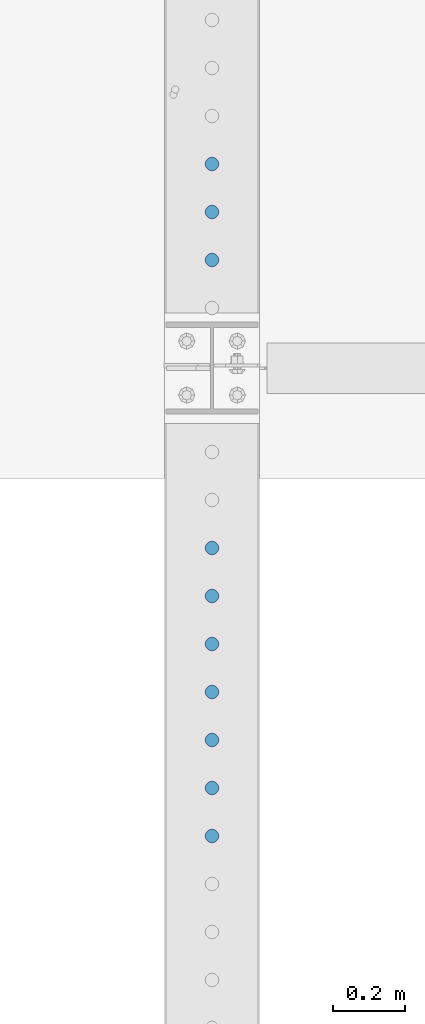
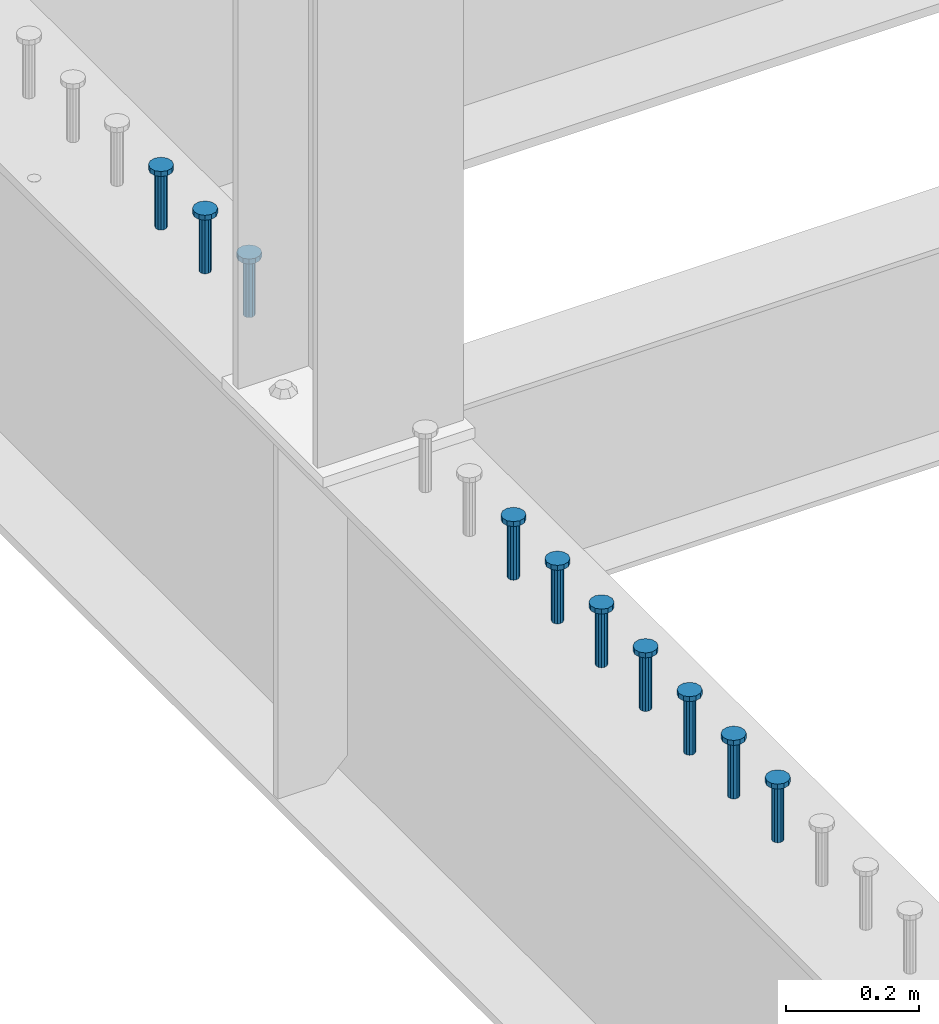
# One storey, part 949 of 1763: 10 columns, 10 elements without a shape of their own.
"""IFC2X3 building model written with IfcOpenShell, lengths in millimetres."""

from ifc_helpers import new_model, si_unit, frame, origin_with_axes, place, context, subcontext, project, spatial, faceted_brep, material, type_object, element, aggregate, save


model = new_model("IFC2X3")

# Units and contexts
model_context = context("Model", 3, precision=1e-05, world=origin_with_axes())
body_context = subcontext(model_context, "Body", "Model", "MODEL_VIEW")
ifc_project = project(units=[si_unit("LENGTHUNIT", "METRE", prefix="MILLI"), si_unit("AREAUNIT", "SQUARE_METRE"), si_unit("VOLUMEUNIT", "CUBIC_METRE"), si_unit("MASSUNIT", "GRAM", prefix="KILO"), si_unit("TIMEUNIT", "SECOND"), si_unit("PLANEANGLEUNIT", "RADIAN"), si_unit("SOLIDANGLEUNIT", "STERADIAN"), si_unit("THERMODYNAMICTEMPERATUREUNIT", "DEGREE_CELSIUS"), si_unit("LUMINOUSINTENSITYUNIT", "LUMEN")], contexts=[model_context])

# Site, building, storey
site_placement = place(None, origin_with_axes())
site = spatial("IfcSite", under=ifc_project, at=site_placement, CompositionType="ELEMENT")
building_placement = place(site_placement, origin_with_axes())
building = spatial("IfcBuilding", under=site, at=building_placement, Name="Undefined", CompositionType="ELEMENT")
storey_placement = place(building_placement, origin_with_axes())
storey = spatial("IfcBuildingStorey", under=building, at=storey_placement, Name="Undefined", CompositionType="ELEMENT", Elevation=0.0)

# Assembly, column
assembly_1_placement = place(storey_placement, origin_with_axes())
assembly_1 = element("IfcElementAssembly", 1, at=assembly_1_placement, inside=storey, Name="STUD", AssemblyPlace="NOTDEFINED", PredefinedType="RIGID_FRAME")
ifc_material = material(Name="STEEL/A108")
column_type = type_object("IfcColumnType", Name="STUD_3/4-DIA", PredefinedType="NOTDEFINED")
column_1_placement = place(assembly_1_placement, frame((-24027.8372736984, 43845.6785, 5194.3), z_axis=(-1.0, 0.0, 0.0), x_axis=(0.0, 0.0, 1.0)))
column_1 = element("IfcColumn", 2, at=column_1_placement, type_object=column_type, material=ifc_material, Name="STUD", ObjectType="STUD_3/4-DIA", context=body_context, shape_type="Brep", body=[
    faceted_brep([(0.0, -9.52000045776367, 0.0), (0.0, -8.25, -4.76000022888184), (104.013, -8.25, -4.76000022888184), (104.013, -9.52000045776367, 0.0), (0.0, -4.76000022888184, -8.25), (104.013, -4.76000022888184, -8.25), (0.0, 0.0, -9.52000045776367), (104.013, 0.0, -9.52000045776367), (0.0, 4.76000022888184, -8.25), (104.013, 4.76000022888184, -8.25), (0.0, 8.25, -4.76000022888184), (104.013, 8.25, -4.76000022888184), (0.0, 9.52000045776367, 0.0), (104.013, 9.52000045776367, 0.0), (0.0, 8.25, 4.76000022888184), (104.013, 8.25, 4.76000022888184), (0.0, 4.76000022888184, 8.25), (104.013, 4.76000022888184, 8.25), (0.0, 0.0, 9.52000045776367), (104.013, 0.0, 9.52000045776367), (0.0, -4.76000022888184, 8.25), (104.013, -4.76000022888184, 8.25), (0.0, -8.25, 4.76000022888184), (104.013, -8.25, 4.76000022888184), (105.156, -16.5, -9.52000045776367), (105.156, -19.0499992370605, 0.0), (105.156, -9.52000045776367, -16.5), (105.156, 0.0, -19.0499992370605), (105.156, 9.52000045776367, -16.5), (105.156, 16.5, -9.52000045776367), (105.156, 19.0499992370605, 0.0), (105.156, 16.5, 9.52000045776367), (105.156, 9.52000045776367, 16.5), (105.156, 0.0, 19.0499992370605), (105.156, -9.52000045776367, 16.5), (105.156, -16.5, 9.52000045776367), (114.3, -16.5, -9.52000045776367), (114.299998441489, -19.0500000000029, 0.0), (114.3, -9.52000045776367, -16.5), (114.3, 0.0, -19.0499992370605), (114.3, 9.52000045776367, -16.5), (114.3, 16.5, -9.52000045776367), (114.299998441489, 19.0500000000029, 0.0), (114.3, 16.5, 9.52000045776367), (114.3, 9.52000045776367, 16.5), (114.3, 0.0, 19.0499992370605), (114.3, -9.52000045776367, 16.5), (114.3, -16.5, 9.52000045776367)], [[[0, 1, 2, 3]], [[1, 4, 5, 2]], [[4, 6, 7, 5]], [[6, 8, 9, 7]], [[8, 10, 11, 9]], [[10, 12, 13, 11]], [[12, 14, 15, 13]], [[14, 16, 17, 15]], [[16, 18, 19, 17]], [[18, 20, 21, 19]], [[20, 22, 23, 21]], [[22, 0, 3, 23]], [[22, 20, 18, 16, 14, 12, 10, 8, 6, 4, 1, 0]], [[3, 2, 24, 25]], [[2, 5, 26, 24]], [[5, 7, 27, 26]], [[7, 9, 28, 27]], [[9, 11, 29, 28]], [[11, 13, 30, 29]], [[13, 15, 31, 30]], [[15, 17, 32, 31]], [[17, 19, 33, 32]], [[19, 21, 34, 33]], [[21, 23, 35, 34]], [[23, 3, 25, 35]], [[25, 24, 36, 37]], [[24, 26, 38, 36]], [[26, 27, 39, 38]], [[27, 28, 40, 39]], [[28, 29, 41, 40]], [[29, 30, 42, 41]], [[30, 31, 43, 42]], [[31, 32, 44, 43]], [[32, 33, 45, 44]], [[33, 34, 46, 45]], [[34, 35, 47, 46]], [[35, 25, 37, 47]], [[38, 39, 40, 41, 42, 43, 44, 45, 46, 47, 37, 36]]]),
])
aggregate(assembly_1, [column_1])

assembly_2_placement = place(storey_placement, origin_with_axes())
assembly_2 = element("IfcElementAssembly", 3, at=assembly_2_placement, inside=storey, Name="STUD", AssemblyPlace="NOTDEFINED", PredefinedType="RIGID_FRAME")
column_2_placement = place(assembly_2_placement, frame((-24027.8372736984, 43713.0705, 5194.3), z_axis=(-1.0, 0.0, 0.0), x_axis=(0.0, 0.0, 1.0)))
column_2 = element("IfcColumn", 4, at=column_2_placement, type_object=column_type, material=ifc_material, Name="STUD", ObjectType="STUD_3/4-DIA", context=body_context, shape_type="Brep", body=[
    faceted_brep([(0.0, -9.52000045776367, 0.0), (0.0, -8.25, -4.76000022888184), (104.013, -8.25, -4.76000022888184), (104.013, -9.52000045776367, 0.0), (0.0, -4.76000022888184, -8.25), (104.013, -4.76000022888184, -8.25), (0.0, 0.0, -9.52000045776367), (104.013, 0.0, -9.52000045776367), (0.0, 4.76000022888184, -8.25), (104.013, 4.76000022888184, -8.25), (0.0, 8.25, -4.76000022888184), (104.013, 8.25, -4.76000022888184), (0.0, 9.52000045776367, 0.0), (104.013, 9.52000045776367, 0.0), (0.0, 8.25, 4.76000022888184), (104.013, 8.25, 4.76000022888184), (0.0, 4.76000022888184, 8.25), (104.013, 4.76000022888184, 8.25), (0.0, 0.0, 9.52000045776367), (104.013, 0.0, 9.52000045776367), (0.0, -4.76000022888184, 8.25), (104.013, -4.76000022888184, 8.25), (0.0, -8.25, 4.76000022888184), (104.013, -8.25, 4.76000022888184), (105.156, -16.5, -9.52000045776367), (105.156, -19.0499992370605, 0.0), (105.156, -9.52000045776367, -16.5), (105.156, 0.0, -19.0499992370605), (105.156, 9.52000045776367, -16.5), (105.156, 16.5, -9.52000045776367), (105.156, 19.0499992370605, 0.0), (105.156, 16.5, 9.52000045776367), (105.156, 9.52000045776367, 16.5), (105.156, 0.0, 19.0499992370605), (105.156, -9.52000045776367, 16.5), (105.156, -16.5, 9.52000045776367), (114.3, -16.5, -9.52000045776367), (114.299998441489, -19.0500000000029, 0.0), (114.3, -9.52000045776367, -16.5), (114.3, 0.0, -19.0499992370605), (114.3, 9.52000045776367, -16.5), (114.3, 16.5, -9.52000045776367), (114.299998441489, 19.0500000000029, 0.0), (114.3, 16.5, 9.52000045776367), (114.3, 9.52000045776367, 16.5), (114.3, 0.0, 19.0499992370605), (114.3, -9.52000045776367, 16.5), (114.3, -16.5, 9.52000045776367)], [[[0, 1, 2, 3]], [[1, 4, 5, 2]], [[4, 6, 7, 5]], [[6, 8, 9, 7]], [[8, 10, 11, 9]], [[10, 12, 13, 11]], [[12, 14, 15, 13]], [[14, 16, 17, 15]], [[16, 18, 19, 17]], [[18, 20, 21, 19]], [[20, 22, 23, 21]], [[22, 0, 3, 23]], [[22, 20, 18, 16, 14, 12, 10, 8, 6, 4, 1, 0]], [[3, 2, 24, 25]], [[2, 5, 26, 24]], [[5, 7, 27, 26]], [[7, 9, 28, 27]], [[9, 11, 29, 28]], [[11, 13, 30, 29]], [[13, 15, 31, 30]], [[15, 17, 32, 31]], [[17, 19, 33, 32]], [[19, 21, 34, 33]], [[21, 23, 35, 34]], [[23, 3, 25, 35]], [[25, 24, 36, 37]], [[24, 26, 38, 36]], [[26, 27, 39, 38]], [[27, 28, 40, 39]], [[28, 29, 41, 40]], [[29, 30, 42, 41]], [[30, 31, 43, 42]], [[31, 32, 44, 43]], [[32, 33, 45, 44]], [[33, 34, 46, 45]], [[34, 35, 47, 46]], [[35, 25, 37, 47]], [[38, 39, 40, 41, 42, 43, 44, 45, 46, 47, 37, 36]]]),
])
aggregate(assembly_2, [column_2])

assembly_3_placement = place(storey_placement, origin_with_axes())
assembly_3 = element("IfcElementAssembly", 5, at=assembly_3_placement, inside=storey, Name="STUD", AssemblyPlace="NOTDEFINED", PredefinedType="RIGID_FRAME")
column_3_placement = place(assembly_3_placement, frame((-24027.8372736984, 43580.4625, 5194.3), z_axis=(-1.0, 0.0, 0.0), x_axis=(0.0, 0.0, 1.0)))
column_3 = element("IfcColumn", 6, at=column_3_placement, type_object=column_type, material=ifc_material, Name="STUD", ObjectType="STUD_3/4-DIA", context=body_context, shape_type="Brep", body=[
    faceted_brep([(0.0, -9.52000045776367, 0.0), (0.0, -8.25, -4.76000022888184), (104.013, -8.25, -4.76000022888184), (104.013, -9.52000045776367, 0.0), (0.0, -4.76000022888184, -8.25), (104.013, -4.76000022888184, -8.25), (0.0, 0.0, -9.52000045776367), (104.013, 0.0, -9.52000045776367), (0.0, 4.76000022888184, -8.25), (104.013, 4.76000022888184, -8.25), (0.0, 8.25, -4.76000022888184), (104.013, 8.25, -4.76000022888184), (0.0, 9.52000045776367, 0.0), (104.013, 9.52000045776367, 0.0), (0.0, 8.25, 4.76000022888184), (104.013, 8.25, 4.76000022888184), (0.0, 4.76000022888184, 8.25), (104.013, 4.76000022888184, 8.25), (0.0, 0.0, 9.52000045776367), (104.013, 0.0, 9.52000045776367), (0.0, -4.76000022888184, 8.25), (104.013, -4.76000022888184, 8.25), (0.0, -8.25, 4.76000022888184), (104.013, -8.25, 4.76000022888184), (105.156, -16.5, -9.52000045776367), (105.156, -19.0499992370605, 0.0), (105.156, -9.52000045776367, -16.5), (105.156, 0.0, -19.0499992370605), (105.156, 9.52000045776367, -16.5), (105.156, 16.5, -9.52000045776367), (105.156, 19.0499992370605, 0.0), (105.156, 16.5, 9.52000045776367), (105.156, 9.52000045776367, 16.5), (105.156, 0.0, 19.0499992370605), (105.156, -9.52000045776367, 16.5), (105.156, -16.5, 9.52000045776367), (114.3, -16.5, -9.52000045776367), (114.299998441489, -19.0500000000029, 0.0), (114.3, -9.52000045776367, -16.5), (114.3, 0.0, -19.0499992370605), (114.3, 9.52000045776367, -16.5), (114.3, 16.5, -9.52000045776367), (114.299998441489, 19.0500000000029, 0.0), (114.3, 16.5, 9.52000045776367), (114.3, 9.52000045776367, 16.5), (114.3, 0.0, 19.0499992370605), (114.3, -9.52000045776367, 16.5), (114.3, -16.5, 9.52000045776367)], [[[0, 1, 2, 3]], [[1, 4, 5, 2]], [[4, 6, 7, 5]], [[6, 8, 9, 7]], [[8, 10, 11, 9]], [[10, 12, 13, 11]], [[12, 14, 15, 13]], [[14, 16, 17, 15]], [[16, 18, 19, 17]], [[18, 20, 21, 19]], [[20, 22, 23, 21]], [[22, 0, 3, 23]], [[22, 20, 18, 16, 14, 12, 10, 8, 6, 4, 1, 0]], [[3, 2, 24, 25]], [[2, 5, 26, 24]], [[5, 7, 27, 26]], [[7, 9, 28, 27]], [[9, 11, 29, 28]], [[11, 13, 30, 29]], [[13, 15, 31, 30]], [[15, 17, 32, 31]], [[17, 19, 33, 32]], [[19, 21, 34, 33]], [[21, 23, 35, 34]], [[23, 3, 25, 35]], [[25, 24, 36, 37]], [[24, 26, 38, 36]], [[26, 27, 39, 38]], [[27, 28, 40, 39]], [[28, 29, 41, 40]], [[29, 30, 42, 41]], [[30, 31, 43, 42]], [[31, 32, 44, 43]], [[32, 33, 45, 44]], [[33, 34, 46, 45]], [[34, 35, 47, 46]], [[35, 25, 37, 47]], [[38, 39, 40, 41, 42, 43, 44, 45, 46, 47, 37, 36]]]),
])
aggregate(assembly_3, [column_3])

assembly_4_placement = place(storey_placement, origin_with_axes())
assembly_4 = element("IfcElementAssembly", 7, at=assembly_4_placement, inside=storey, Name="STUD", AssemblyPlace="NOTDEFINED", PredefinedType="RIGID_FRAME")
column_4_placement = place(assembly_4_placement, frame((-24027.8372736984, 42784.8145, 5194.3), z_axis=(-1.0, 0.0, 0.0), x_axis=(0.0, 0.0, 1.0)))
column_4 = element("IfcColumn", 8, at=column_4_placement, type_object=column_type, material=ifc_material, Name="STUD", ObjectType="STUD_3/4-DIA", context=body_context, shape_type="Brep", body=[
    faceted_brep([(0.0, -9.52000045776367, 0.0), (0.0, -8.25, -4.76000022888184), (104.013, -8.25, -4.76000022888184), (104.013, -9.52000045776367, 0.0), (0.0, -4.76000022888184, -8.25), (104.013, -4.76000022888184, -8.25), (0.0, 0.0, -9.52000045776367), (104.013, 0.0, -9.52000045776367), (0.0, 4.76000022888184, -8.25), (104.013, 4.76000022888184, -8.25), (0.0, 8.25, -4.76000022888184), (104.013, 8.25, -4.76000022888184), (0.0, 9.52000045776367, 0.0), (104.013, 9.52000045776367, 0.0), (0.0, 8.25, 4.76000022888184), (104.013, 8.25, 4.76000022888184), (0.0, 4.76000022888184, 8.25), (104.013, 4.76000022888184, 8.25), (0.0, 0.0, 9.52000045776367), (104.013, 0.0, 9.52000045776367), (0.0, -4.76000022888184, 8.25), (104.013, -4.76000022888184, 8.25), (0.0, -8.25, 4.76000022888184), (104.013, -8.25, 4.76000022888184), (105.156, -16.5, -9.52000045776367), (105.156, -19.0499992370605, 0.0), (105.156, -9.52000045776367, -16.5), (105.156, 0.0, -19.0499992370605), (105.156, 9.52000045776367, -16.5), (105.156, 16.5, -9.52000045776367), (105.156, 19.0499992370605, 0.0), (105.156, 16.5, 9.52000045776367), (105.156, 9.52000045776367, 16.5), (105.156, 0.0, 19.0499992370605), (105.156, -9.52000045776367, 16.5), (105.156, -16.5, 9.52000045776367), (114.3, -16.5, -9.52000045776367), (114.299998441489, -19.0500000000029, 0.0), (114.3, -9.52000045776367, -16.5), (114.3, 0.0, -19.0499992370605), (114.3, 9.52000045776367, -16.5), (114.3, 16.5, -9.52000045776367), (114.299998441489, 19.0500000000029, 0.0), (114.3, 16.5, 9.52000045776367), (114.3, 9.52000045776367, 16.5), (114.3, 0.0, 19.0499992370605), (114.3, -9.52000045776367, 16.5), (114.3, -16.5, 9.52000045776367)], [[[0, 1, 2, 3]], [[1, 4, 5, 2]], [[4, 6, 7, 5]], [[6, 8, 9, 7]], [[8, 10, 11, 9]], [[10, 12, 13, 11]], [[12, 14, 15, 13]], [[14, 16, 17, 15]], [[16, 18, 19, 17]], [[18, 20, 21, 19]], [[20, 22, 23, 21]], [[22, 0, 3, 23]], [[22, 20, 18, 16, 14, 12, 10, 8, 6, 4, 1, 0]], [[3, 2, 24, 25]], [[2, 5, 26, 24]], [[5, 7, 27, 26]], [[7, 9, 28, 27]], [[9, 11, 29, 28]], [[11, 13, 30, 29]], [[13, 15, 31, 30]], [[15, 17, 32, 31]], [[17, 19, 33, 32]], [[19, 21, 34, 33]], [[21, 23, 35, 34]], [[23, 3, 25, 35]], [[25, 24, 36, 37]], [[24, 26, 38, 36]], [[26, 27, 39, 38]], [[27, 28, 40, 39]], [[28, 29, 41, 40]], [[29, 30, 42, 41]], [[30, 31, 43, 42]], [[31, 32, 44, 43]], [[32, 33, 45, 44]], [[33, 34, 46, 45]], [[34, 35, 47, 46]], [[35, 25, 37, 47]], [[38, 39, 40, 41, 42, 43, 44, 45, 46, 47, 37, 36]]]),
])
aggregate(assembly_4, [column_4])

assembly_5_placement = place(storey_placement, origin_with_axes())
assembly_5 = element("IfcElementAssembly", 9, at=assembly_5_placement, inside=storey, Name="STUD", AssemblyPlace="NOTDEFINED", PredefinedType="RIGID_FRAME")
column_5_placement = place(assembly_5_placement, frame((-24027.8372736984, 42652.2065, 5194.3), z_axis=(-1.0, 0.0, 0.0), x_axis=(0.0, 0.0, 1.0)))
column_5 = element("IfcColumn", 10, at=column_5_placement, type_object=column_type, material=ifc_material, Name="STUD", ObjectType="STUD_3/4-DIA", context=body_context, shape_type="Brep", body=[
    faceted_brep([(0.0, -9.52000045776367, 0.0), (0.0, -8.25, -4.76000022888184), (104.013, -8.25, -4.76000022888184), (104.013, -9.52000045776367, 0.0), (0.0, -4.76000022888184, -8.25), (104.013, -4.76000022888184, -8.25), (0.0, 0.0, -9.52000045776367), (104.013, 0.0, -9.52000045776367), (0.0, 4.76000022888184, -8.25), (104.013, 4.76000022888184, -8.25), (0.0, 8.25, -4.76000022888184), (104.013, 8.25, -4.76000022888184), (0.0, 9.52000045776367, 0.0), (104.013, 9.52000045776367, 0.0), (0.0, 8.25, 4.76000022888184), (104.013, 8.25, 4.76000022888184), (0.0, 4.76000022888184, 8.25), (104.013, 4.76000022888184, 8.25), (0.0, 0.0, 9.52000045776367), (104.013, 0.0, 9.52000045776367), (0.0, -4.76000022888184, 8.25), (104.013, -4.76000022888184, 8.25), (0.0, -8.25, 4.76000022888184), (104.013, -8.25, 4.76000022888184), (105.156, -16.5, -9.52000045776367), (105.156, -19.0499992370605, 0.0), (105.156, -9.52000045776367, -16.5), (105.156, 0.0, -19.0499992370605), (105.156, 9.52000045776367, -16.5), (105.156, 16.5, -9.52000045776367), (105.156, 19.0499992370605, 0.0), (105.156, 16.5, 9.52000045776367), (105.156, 9.52000045776367, 16.5), (105.156, 0.0, 19.0499992370605), (105.156, -9.52000045776367, 16.5), (105.156, -16.5, 9.52000045776367), (114.3, -16.5, -9.52000045776367), (114.299998441489, -19.0500000000029, 0.0), (114.3, -9.52000045776367, -16.5), (114.3, 0.0, -19.0499992370605), (114.3, 9.52000045776367, -16.5), (114.3, 16.5, -9.52000045776367), (114.299998441489, 19.0500000000029, 0.0), (114.3, 16.5, 9.52000045776367), (114.3, 9.52000045776367, 16.5), (114.3, 0.0, 19.0499992370605), (114.3, -9.52000045776367, 16.5), (114.3, -16.5, 9.52000045776367)], [[[0, 1, 2, 3]], [[1, 4, 5, 2]], [[4, 6, 7, 5]], [[6, 8, 9, 7]], [[8, 10, 11, 9]], [[10, 12, 13, 11]], [[12, 14, 15, 13]], [[14, 16, 17, 15]], [[16, 18, 19, 17]], [[18, 20, 21, 19]], [[20, 22, 23, 21]], [[22, 0, 3, 23]], [[22, 20, 18, 16, 14, 12, 10, 8, 6, 4, 1, 0]], [[3, 2, 24, 25]], [[2, 5, 26, 24]], [[5, 7, 27, 26]], [[7, 9, 28, 27]], [[9, 11, 29, 28]], [[11, 13, 30, 29]], [[13, 15, 31, 30]], [[15, 17, 32, 31]], [[17, 19, 33, 32]], [[19, 21, 34, 33]], [[21, 23, 35, 34]], [[23, 3, 25, 35]], [[25, 24, 36, 37]], [[24, 26, 38, 36]], [[26, 27, 39, 38]], [[27, 28, 40, 39]], [[28, 29, 41, 40]], [[29, 30, 42, 41]], [[30, 31, 43, 42]], [[31, 32, 44, 43]], [[32, 33, 45, 44]], [[33, 34, 46, 45]], [[34, 35, 47, 46]], [[35, 25, 37, 47]], [[38, 39, 40, 41, 42, 43, 44, 45, 46, 47, 37, 36]]]),
])
aggregate(assembly_5, [column_5])

assembly_6_placement = place(storey_placement, origin_with_axes())
assembly_6 = element("IfcElementAssembly", 11, at=assembly_6_placement, inside=storey, Name="STUD", AssemblyPlace="NOTDEFINED", PredefinedType="RIGID_FRAME")
column_6_placement = place(assembly_6_placement, frame((-24027.8372736984, 42519.5985, 5194.3), z_axis=(-1.0, 0.0, 0.0), x_axis=(0.0, 0.0, 1.0)))
column_6 = element("IfcColumn", 12, at=column_6_placement, type_object=column_type, material=ifc_material, Name="STUD", ObjectType="STUD_3/4-DIA", context=body_context, shape_type="Brep", body=[
    faceted_brep([(0.0, -9.52000045776367, 0.0), (0.0, -8.25, -4.76000022888184), (104.013, -8.25, -4.76000022888184), (104.013, -9.52000045776367, 0.0), (0.0, -4.76000022888184, -8.25), (104.013, -4.76000022888184, -8.25), (0.0, 0.0, -9.52000045776367), (104.013, 0.0, -9.52000045776367), (0.0, 4.76000022888184, -8.25), (104.013, 4.76000022888184, -8.25), (0.0, 8.25, -4.76000022888184), (104.013, 8.25, -4.76000022888184), (0.0, 9.52000045776367, 0.0), (104.013, 9.52000045776367, 0.0), (0.0, 8.25, 4.76000022888184), (104.013, 8.25, 4.76000022888184), (0.0, 4.76000022888184, 8.25), (104.013, 4.76000022888184, 8.25), (0.0, 0.0, 9.52000045776367), (104.013, 0.0, 9.52000045776367), (0.0, -4.76000022888184, 8.25), (104.013, -4.76000022888184, 8.25), (0.0, -8.25, 4.76000022888184), (104.013, -8.25, 4.76000022888184), (105.156, -16.5, -9.52000045776367), (105.156, -19.0499992370605, 0.0), (105.156, -9.52000045776367, -16.5), (105.156, 0.0, -19.0499992370605), (105.156, 9.52000045776367, -16.5), (105.156, 16.5, -9.52000045776367), (105.156, 19.0499992370605, 0.0), (105.156, 16.5, 9.52000045776367), (105.156, 9.52000045776367, 16.5), (105.156, 0.0, 19.0499992370605), (105.156, -9.52000045776367, 16.5), (105.156, -16.5, 9.52000045776367), (114.3, -16.5, -9.52000045776367), (114.299998441489, -19.0500000000029, 0.0), (114.3, -9.52000045776367, -16.5), (114.3, 0.0, -19.0499992370605), (114.3, 9.52000045776367, -16.5), (114.3, 16.5, -9.52000045776367), (114.299998441489, 19.0500000000029, 0.0), (114.3, 16.5, 9.52000045776367), (114.3, 9.52000045776367, 16.5), (114.3, 0.0, 19.0499992370605), (114.3, -9.52000045776367, 16.5), (114.3, -16.5, 9.52000045776367)], [[[0, 1, 2, 3]], [[1, 4, 5, 2]], [[4, 6, 7, 5]], [[6, 8, 9, 7]], [[8, 10, 11, 9]], [[10, 12, 13, 11]], [[12, 14, 15, 13]], [[14, 16, 17, 15]], [[16, 18, 19, 17]], [[18, 20, 21, 19]], [[20, 22, 23, 21]], [[22, 0, 3, 23]], [[22, 20, 18, 16, 14, 12, 10, 8, 6, 4, 1, 0]], [[3, 2, 24, 25]], [[2, 5, 26, 24]], [[5, 7, 27, 26]], [[7, 9, 28, 27]], [[9, 11, 29, 28]], [[11, 13, 30, 29]], [[13, 15, 31, 30]], [[15, 17, 32, 31]], [[17, 19, 33, 32]], [[19, 21, 34, 33]], [[21, 23, 35, 34]], [[23, 3, 25, 35]], [[25, 24, 36, 37]], [[24, 26, 38, 36]], [[26, 27, 39, 38]], [[27, 28, 40, 39]], [[28, 29, 41, 40]], [[29, 30, 42, 41]], [[30, 31, 43, 42]], [[31, 32, 44, 43]], [[32, 33, 45, 44]], [[33, 34, 46, 45]], [[34, 35, 47, 46]], [[35, 25, 37, 47]], [[38, 39, 40, 41, 42, 43, 44, 45, 46, 47, 37, 36]]]),
])
aggregate(assembly_6, [column_6])

assembly_7_placement = place(storey_placement, origin_with_axes())
assembly_7 = element("IfcElementAssembly", 13, at=assembly_7_placement, inside=storey, Name="STUD", AssemblyPlace="NOTDEFINED", PredefinedType="RIGID_FRAME")
column_7_placement = place(assembly_7_placement, frame((-24027.8372736984, 42386.9905, 5194.3), z_axis=(-1.0, 0.0, 0.0), x_axis=(0.0, 0.0, 1.0)))
column_7 = element("IfcColumn", 14, at=column_7_placement, type_object=column_type, material=ifc_material, Name="STUD", ObjectType="STUD_3/4-DIA", context=body_context, shape_type="Brep", body=[
    faceted_brep([(0.0, -9.52000045776367, 0.0), (0.0, -8.25, -4.76000022888184), (104.013, -8.25, -4.76000022888184), (104.013, -9.52000045776367, 0.0), (0.0, -4.76000022888184, -8.25), (104.013, -4.76000022888184, -8.25), (0.0, 0.0, -9.52000045776367), (104.013, 0.0, -9.52000045776367), (0.0, 4.76000022888184, -8.25), (104.013, 4.76000022888184, -8.25), (0.0, 8.25, -4.76000022888184), (104.013, 8.25, -4.76000022888184), (0.0, 9.52000045776367, 0.0), (104.013, 9.52000045776367, 0.0), (0.0, 8.25, 4.76000022888184), (104.013, 8.25, 4.76000022888184), (0.0, 4.76000022888184, 8.25), (104.013, 4.76000022888184, 8.25), (0.0, 0.0, 9.52000045776367), (104.013, 0.0, 9.52000045776367), (0.0, -4.76000022888184, 8.25), (104.013, -4.76000022888184, 8.25), (0.0, -8.25, 4.76000022888184), (104.013, -8.25, 4.76000022888184), (105.156, -16.5, -9.52000045776367), (105.156, -19.0499992370605, 0.0), (105.156, -9.52000045776367, -16.5), (105.156, 0.0, -19.0499992370605), (105.156, 9.52000045776367, -16.5), (105.156, 16.5, -9.52000045776367), (105.156, 19.0499992370605, 0.0), (105.156, 16.5, 9.52000045776367), (105.156, 9.52000045776367, 16.5), (105.156, 0.0, 19.0499992370605), (105.156, -9.52000045776367, 16.5), (105.156, -16.5, 9.52000045776367), (114.3, -16.5, -9.52000045776367), (114.299998441489, -19.0500000000029, 0.0), (114.3, -9.52000045776367, -16.5), (114.3, 0.0, -19.0499992370605), (114.3, 9.52000045776367, -16.5), (114.3, 16.5, -9.52000045776367), (114.299998441489, 19.0500000000029, 0.0), (114.3, 16.5, 9.52000045776367), (114.3, 9.52000045776367, 16.5), (114.3, 0.0, 19.0499992370605), (114.3, -9.52000045776367, 16.5), (114.3, -16.5, 9.52000045776367)], [[[0, 1, 2, 3]], [[1, 4, 5, 2]], [[4, 6, 7, 5]], [[6, 8, 9, 7]], [[8, 10, 11, 9]], [[10, 12, 13, 11]], [[12, 14, 15, 13]], [[14, 16, 17, 15]], [[16, 18, 19, 17]], [[18, 20, 21, 19]], [[20, 22, 23, 21]], [[22, 0, 3, 23]], [[22, 20, 18, 16, 14, 12, 10, 8, 6, 4, 1, 0]], [[3, 2, 24, 25]], [[2, 5, 26, 24]], [[5, 7, 27, 26]], [[7, 9, 28, 27]], [[9, 11, 29, 28]], [[11, 13, 30, 29]], [[13, 15, 31, 30]], [[15, 17, 32, 31]], [[17, 19, 33, 32]], [[19, 21, 34, 33]], [[21, 23, 35, 34]], [[23, 3, 25, 35]], [[25, 24, 36, 37]], [[24, 26, 38, 36]], [[26, 27, 39, 38]], [[27, 28, 40, 39]], [[28, 29, 41, 40]], [[29, 30, 42, 41]], [[30, 31, 43, 42]], [[31, 32, 44, 43]], [[32, 33, 45, 44]], [[33, 34, 46, 45]], [[34, 35, 47, 46]], [[35, 25, 37, 47]], [[38, 39, 40, 41, 42, 43, 44, 45, 46, 47, 37, 36]]]),
])
aggregate(assembly_7, [column_7])

assembly_8_placement = place(storey_placement, origin_with_axes())
assembly_8 = element("IfcElementAssembly", 15, at=assembly_8_placement, inside=storey, Name="STUD", AssemblyPlace="NOTDEFINED", PredefinedType="RIGID_FRAME")
column_8_placement = place(assembly_8_placement, frame((-24027.8372736984, 42254.3825, 5194.3), z_axis=(-1.0, 0.0, 0.0), x_axis=(0.0, 0.0, 1.0)))
column_8 = element("IfcColumn", 16, at=column_8_placement, type_object=column_type, material=ifc_material, Name="STUD", ObjectType="STUD_3/4-DIA", context=body_context, shape_type="Brep", body=[
    faceted_brep([(0.0, -9.52000045776367, 0.0), (0.0, -8.25, -4.76000022888184), (104.013, -8.25, -4.76000022888184), (104.013, -9.52000045776367, 0.0), (0.0, -4.76000022888184, -8.25), (104.013, -4.76000022888184, -8.25), (0.0, 0.0, -9.52000045776367), (104.013, 0.0, -9.52000045776367), (0.0, 4.76000022888184, -8.25), (104.013, 4.76000022888184, -8.25), (0.0, 8.25, -4.76000022888184), (104.013, 8.25, -4.76000022888184), (0.0, 9.52000045776367, 0.0), (104.013, 9.52000045776367, 0.0), (0.0, 8.25, 4.76000022888184), (104.013, 8.25, 4.76000022888184), (0.0, 4.76000022888184, 8.25), (104.013, 4.76000022888184, 8.25), (0.0, 0.0, 9.52000045776367), (104.013, 0.0, 9.52000045776367), (0.0, -4.76000022888184, 8.25), (104.013, -4.76000022888184, 8.25), (0.0, -8.25, 4.76000022888184), (104.013, -8.25, 4.76000022888184), (105.156, -16.5, -9.52000045776367), (105.156, -19.0499992370605, 0.0), (105.156, -9.52000045776367, -16.5), (105.156, 0.0, -19.0499992370605), (105.156, 9.52000045776367, -16.5), (105.156, 16.5, -9.52000045776367), (105.156, 19.0499992370605, 0.0), (105.156, 16.5, 9.52000045776367), (105.156, 9.52000045776367, 16.5), (105.156, 0.0, 19.0499992370605), (105.156, -9.52000045776367, 16.5), (105.156, -16.5, 9.52000045776367), (114.3, -16.5, -9.52000045776367), (114.299998441489, -19.0500000000029, 0.0), (114.3, -9.52000045776367, -16.5), (114.3, 0.0, -19.0499992370605), (114.3, 9.52000045776367, -16.5), (114.3, 16.5, -9.52000045776367), (114.299998441489, 19.0500000000029, 0.0), (114.3, 16.5, 9.52000045776367), (114.3, 9.52000045776367, 16.5), (114.3, 0.0, 19.0499992370605), (114.3, -9.52000045776367, 16.5), (114.3, -16.5, 9.52000045776367)], [[[0, 1, 2, 3]], [[1, 4, 5, 2]], [[4, 6, 7, 5]], [[6, 8, 9, 7]], [[8, 10, 11, 9]], [[10, 12, 13, 11]], [[12, 14, 15, 13]], [[14, 16, 17, 15]], [[16, 18, 19, 17]], [[18, 20, 21, 19]], [[20, 22, 23, 21]], [[22, 0, 3, 23]], [[22, 20, 18, 16, 14, 12, 10, 8, 6, 4, 1, 0]], [[3, 2, 24, 25]], [[2, 5, 26, 24]], [[5, 7, 27, 26]], [[7, 9, 28, 27]], [[9, 11, 29, 28]], [[11, 13, 30, 29]], [[13, 15, 31, 30]], [[15, 17, 32, 31]], [[17, 19, 33, 32]], [[19, 21, 34, 33]], [[21, 23, 35, 34]], [[23, 3, 25, 35]], [[25, 24, 36, 37]], [[24, 26, 38, 36]], [[26, 27, 39, 38]], [[27, 28, 40, 39]], [[28, 29, 41, 40]], [[29, 30, 42, 41]], [[30, 31, 43, 42]], [[31, 32, 44, 43]], [[32, 33, 45, 44]], [[33, 34, 46, 45]], [[34, 35, 47, 46]], [[35, 25, 37, 47]], [[38, 39, 40, 41, 42, 43, 44, 45, 46, 47, 37, 36]]]),
])
aggregate(assembly_8, [column_8])

assembly_9_placement = place(storey_placement, origin_with_axes())
assembly_9 = element("IfcElementAssembly", 17, at=assembly_9_placement, inside=storey, Name="STUD", AssemblyPlace="NOTDEFINED", PredefinedType="RIGID_FRAME")
column_9_placement = place(assembly_9_placement, frame((-24027.8372736984, 42121.7745, 5194.3), z_axis=(-1.0, 0.0, 0.0), x_axis=(0.0, 0.0, 1.0)))
column_9 = element("IfcColumn", 18, at=column_9_placement, type_object=column_type, material=ifc_material, Name="STUD", ObjectType="STUD_3/4-DIA", context=body_context, shape_type="Brep", body=[
    faceted_brep([(0.0, -9.52000045776367, 0.0), (0.0, -8.25, -4.76000022888184), (104.013, -8.25, -4.76000022888184), (104.013, -9.52000045776367, 0.0), (0.0, -4.76000022888184, -8.25), (104.013, -4.76000022888184, -8.25), (0.0, 0.0, -9.52000045776367), (104.013, 0.0, -9.52000045776367), (0.0, 4.76000022888184, -8.25), (104.013, 4.76000022888184, -8.25), (0.0, 8.25, -4.76000022888184), (104.013, 8.25, -4.76000022888184), (0.0, 9.52000045776367, 0.0), (104.013, 9.52000045776367, 0.0), (0.0, 8.25, 4.76000022888184), (104.013, 8.25, 4.76000022888184), (0.0, 4.76000022888184, 8.25), (104.013, 4.76000022888184, 8.25), (0.0, 0.0, 9.52000045776367), (104.013, 0.0, 9.52000045776367), (0.0, -4.76000022888184, 8.25), (104.013, -4.76000022888184, 8.25), (0.0, -8.25, 4.76000022888184), (104.013, -8.25, 4.76000022888184), (105.156, -16.5, -9.52000045776367), (105.156, -19.0499992370605, 0.0), (105.156, -9.52000045776367, -16.5), (105.156, 0.0, -19.0499992370605), (105.156, 9.52000045776367, -16.5), (105.156, 16.5, -9.52000045776367), (105.156, 19.0499992370605, 0.0), (105.156, 16.5, 9.52000045776367), (105.156, 9.52000045776367, 16.5), (105.156, 0.0, 19.0499992370605), (105.156, -9.52000045776367, 16.5), (105.156, -16.5, 9.52000045776367), (114.3, -16.5, -9.52000045776367), (114.299998441489, -19.0500000000029, 0.0), (114.3, -9.52000045776367, -16.5), (114.3, 0.0, -19.0499992370605), (114.3, 9.52000045776367, -16.5), (114.3, 16.5, -9.52000045776367), (114.299998441489, 19.0500000000029, 0.0), (114.3, 16.5, 9.52000045776367), (114.3, 9.52000045776367, 16.5), (114.3, 0.0, 19.0499992370605), (114.3, -9.52000045776367, 16.5), (114.3, -16.5, 9.52000045776367)], [[[0, 1, 2, 3]], [[1, 4, 5, 2]], [[4, 6, 7, 5]], [[6, 8, 9, 7]], [[8, 10, 11, 9]], [[10, 12, 13, 11]], [[12, 14, 15, 13]], [[14, 16, 17, 15]], [[16, 18, 19, 17]], [[18, 20, 21, 19]], [[20, 22, 23, 21]], [[22, 0, 3, 23]], [[22, 20, 18, 16, 14, 12, 10, 8, 6, 4, 1, 0]], [[3, 2, 24, 25]], [[2, 5, 26, 24]], [[5, 7, 27, 26]], [[7, 9, 28, 27]], [[9, 11, 29, 28]], [[11, 13, 30, 29]], [[13, 15, 31, 30]], [[15, 17, 32, 31]], [[17, 19, 33, 32]], [[19, 21, 34, 33]], [[21, 23, 35, 34]], [[23, 3, 25, 35]], [[25, 24, 36, 37]], [[24, 26, 38, 36]], [[26, 27, 39, 38]], [[27, 28, 40, 39]], [[28, 29, 41, 40]], [[29, 30, 42, 41]], [[30, 31, 43, 42]], [[31, 32, 44, 43]], [[32, 33, 45, 44]], [[33, 34, 46, 45]], [[34, 35, 47, 46]], [[35, 25, 37, 47]], [[38, 39, 40, 41, 42, 43, 44, 45, 46, 47, 37, 36]]]),
])
aggregate(assembly_9, [column_9])

assembly_10_placement = place(storey_placement, origin_with_axes())
assembly_10 = element("IfcElementAssembly", 19, at=assembly_10_placement, inside=storey, Name="STUD", AssemblyPlace="NOTDEFINED", PredefinedType="RIGID_FRAME")
column_10_placement = place(assembly_10_placement, frame((-24027.8372736984, 41989.1665, 5194.3), z_axis=(-1.0, 0.0, 0.0), x_axis=(0.0, 0.0, 1.0)))
column_10 = element("IfcColumn", 20, at=column_10_placement, type_object=column_type, material=ifc_material, Name="STUD", ObjectType="STUD_3/4-DIA", context=body_context, shape_type="Brep", body=[
    faceted_brep([(0.0, -9.52000045776367, 0.0), (0.0, -8.25, -4.76000022888184), (104.013, -8.25, -4.76000022888184), (104.013, -9.52000045776367, 0.0), (0.0, -4.76000022888184, -8.25), (104.013, -4.76000022888184, -8.25), (0.0, 0.0, -9.52000045776367), (104.013, 0.0, -9.52000045776367), (0.0, 4.76000022888184, -8.25), (104.013, 4.76000022888184, -8.25), (0.0, 8.25, -4.76000022888184), (104.013, 8.25, -4.76000022888184), (0.0, 9.52000045776367, 0.0), (104.013, 9.52000045776367, 0.0), (0.0, 8.25, 4.76000022888184), (104.013, 8.25, 4.76000022888184), (0.0, 4.76000022888184, 8.25), (104.013, 4.76000022888184, 8.25), (0.0, 0.0, 9.52000045776367), (104.013, 0.0, 9.52000045776367), (0.0, -4.76000022888184, 8.25), (104.013, -4.76000022888184, 8.25), (0.0, -8.25, 4.76000022888184), (104.013, -8.25, 4.76000022888184), (105.156, -16.5, -9.52000045776367), (105.156, -19.0499992370605, 0.0), (105.156, -9.52000045776367, -16.5), (105.156, 0.0, -19.0499992370605), (105.156, 9.52000045776367, -16.5), (105.156, 16.5, -9.52000045776367), (105.156, 19.0499992370605, 0.0), (105.156, 16.5, 9.52000045776367), (105.156, 9.52000045776367, 16.5), (105.156, 0.0, 19.0499992370605), (105.156, -9.52000045776367, 16.5), (105.156, -16.5, 9.52000045776367), (114.3, -16.5, -9.52000045776367), (114.299998441489, -19.0500000000029, 0.0), (114.3, -9.52000045776367, -16.5), (114.3, 0.0, -19.0499992370605), (114.3, 9.52000045776367, -16.5), (114.3, 16.5, -9.52000045776367), (114.299998441489, 19.0500000000029, 0.0), (114.3, 16.5, 9.52000045776367), (114.3, 9.52000045776367, 16.5), (114.3, 0.0, 19.0499992370605), (114.3, -9.52000045776367, 16.5), (114.3, -16.5, 9.52000045776367)], [[[0, 1, 2, 3]], [[1, 4, 5, 2]], [[4, 6, 7, 5]], [[6, 8, 9, 7]], [[8, 10, 11, 9]], [[10, 12, 13, 11]], [[12, 14, 15, 13]], [[14, 16, 17, 15]], [[16, 18, 19, 17]], [[18, 20, 21, 19]], [[20, 22, 23, 21]], [[22, 0, 3, 23]], [[22, 20, 18, 16, 14, 12, 10, 8, 6, 4, 1, 0]], [[3, 2, 24, 25]], [[2, 5, 26, 24]], [[5, 7, 27, 26]], [[7, 9, 28, 27]], [[9, 11, 29, 28]], [[11, 13, 30, 29]], [[13, 15, 31, 30]], [[15, 17, 32, 31]], [[17, 19, 33, 32]], [[19, 21, 34, 33]], [[21, 23, 35, 34]], [[23, 3, 25, 35]], [[25, 24, 36, 37]], [[24, 26, 38, 36]], [[26, 27, 39, 38]], [[27, 28, 40, 39]], [[28, 29, 41, 40]], [[29, 30, 42, 41]], [[30, 31, 43, 42]], [[31, 32, 44, 43]], [[32, 33, 45, 44]], [[33, 34, 46, 45]], [[34, 35, 47, 46]], [[35, 25, 37, 47]], [[38, 39, 40, 41, 42, 43, 44, 45, 46, 47, 37, 36]]]),
])
aggregate(assembly_10, [column_10])

save(model, "model.ifc")
